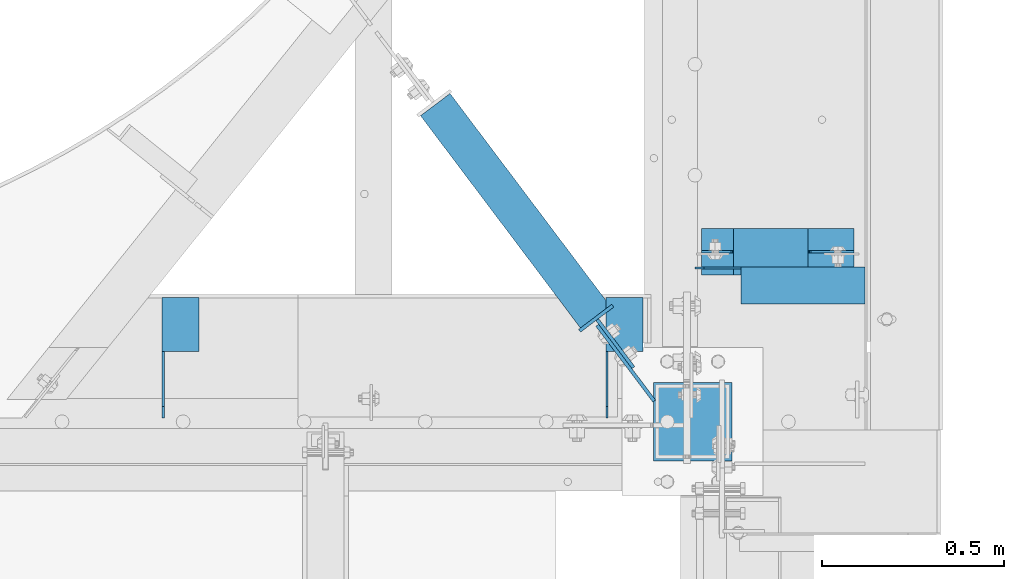
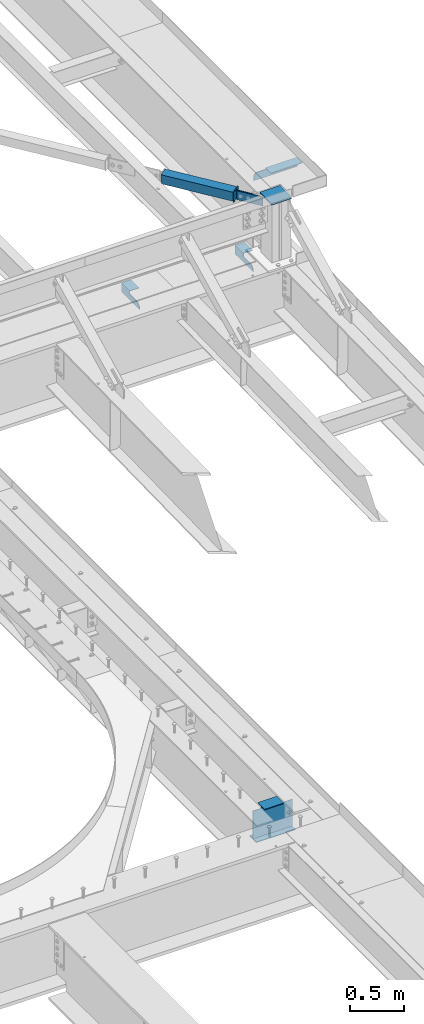
# One storey, part 1377 of 1763: 9 beams, 5 elements without a shape of their own.
"""IFC2X3 building model written with IfcOpenShell, lengths in millimetres."""

from ifc_helpers import new_model, si_unit, frame, origin_with_axes, place, context, subcontext, project, spatial, faceted_brep, material, type_object, element, aggregate, save


model = new_model("IFC2X3")

# Units and contexts
model_context = context("Model", 3, precision=1e-05, world=origin_with_axes())
body_context = subcontext(model_context, "Body", "Model", "MODEL_VIEW")
ifc_project = project(units=[si_unit("LENGTHUNIT", "METRE", prefix="MILLI"), si_unit("AREAUNIT", "SQUARE_METRE"), si_unit("VOLUMEUNIT", "CUBIC_METRE"), si_unit("MASSUNIT", "GRAM", prefix="KILO"), si_unit("TIMEUNIT", "SECOND"), si_unit("PLANEANGLEUNIT", "RADIAN"), si_unit("SOLIDANGLEUNIT", "STERADIAN"), si_unit("THERMODYNAMICTEMPERATUREUNIT", "DEGREE_CELSIUS"), si_unit("LUMINOUSINTENSITYUNIT", "LUMEN")], contexts=[model_context])

# Site, building, storey
site_placement = place(None, origin_with_axes())
site = spatial("IfcSite", under=ifc_project, at=site_placement, CompositionType="ELEMENT")
building_placement = place(site_placement, origin_with_axes())
building = spatial("IfcBuilding", under=site, at=building_placement, Name="Undefined", CompositionType="ELEMENT")
storey_placement = place(building_placement, origin_with_axes())
storey = spatial("IfcBuildingStorey", under=building, at=storey_placement, Name="Undefined", CompositionType="ELEMENT", Elevation=0.0)

# Assembly, beam
assembly_1_placement = place(storey_placement, origin_with_axes())
assembly_1 = element("IfcElementAssembly", 1, at=assembly_1_placement, inside=storey, Name="BEAM", AssemblyPlace="NOTDEFINED", PredefinedType="RIGID_FRAME")
ifc_material_1 = material(Name="STEEL/A36")
beam_type_1 = type_object("IfcBeamType", Name="L4X4X1/4", PredefinedType="NOTDEFINED")
beam_1_placement = place(assembly_1_placement, frame((-21196.9646113448, 52495.4499880058, 12395.2), z_axis=(0.0, 0.0, -1.0), x_axis=(-1.0, 0.0, 0.0)))
beam_1 = element("IfcBeam", 2, at=beam_1_placement, type_object=beam_type_1, material=ifc_material_1, Name="BRACE", ObjectType="L4X4X1/4", context=body_context, shape_type="Brep", body=[
    faceted_brep([(1.96450855582952e-10, -50.8000000000338, -44.4499999999534), (2.11002770811319e-10, -50.8000000000357, -50.799999999952), (339.725506103507, -50.8000000000029, -50.7999999999993), (339.725506103507, -50.8000000000029, -44.4500000000007), (-3.63797880709171e-11, 50.8000000000011, -50.8000000000538), (339.725506103507, 50.8000000000029, -50.7999999999993), (339.725506103507, 44.4499999999971, -34.9250007629398), (339.725506103507, 50.8000000000029, -34.9250007629398), (441.325002944937, 50.8000000000029, -34.9250007629398), (441.325002944937, 44.4499999999971, -34.9250007629398), (339.725506103507, 44.4499999999971, -44.4500000000007), (-2.18278728425503e-11, 44.4500000000007, -44.450000000048), (-1.81898940354586e-10, 44.4500000000371, 50.7999999999374), (-1.96450855582952e-10, 50.8000000000393, 50.7999999999374), (466.725006103512, 44.4499999999971, 50.7999999999993), (466.725006103512, 50.8000000000029, 50.7999999999993), (466.725002563468, 50.8000000000029, -9.52499923706091), (466.725002563468, 44.4499999999971, -9.52499923706091)], [[[0, 1, 2, 3]], [[1, 4, 5, 2]], [[6, 7, 8, 9]], [[10, 3, 2, 5, 7, 6]], [[11, 0, 3, 10]], [[1, 0, 11, 12, 13, 4]], [[13, 12, 14, 15]], [[8, 7, 5, 4, 13, 15, 16]], [[9, 8, 16, 17]], [[12, 11, 10, 6, 9, 17, 14]], [[16, 15, 14, 17]]]),
])
aggregate(assembly_1, [beam_1])

# Assembly, beams
assembly_2_placement = place(storey_placement, origin_with_axes())
assembly_2 = element("IfcElementAssembly", 3, at=assembly_2_placement, inside=storey, Name="BEAM", AssemblyPlace="NOTDEFINED", PredefinedType="RIGID_FRAME")
beam_2_placement = place(assembly_2_placement, frame((-21857.7247736984, 52462.1124819023, 11696.6999917654), z_axis=(0.0, 0.0, -1.0), x_axis=(0.0, -1.0, 0.0)))
beam_2 = element("IfcBeam", 4, at=beam_2_placement, type_object=beam_type_1, material=ifc_material_1, Name="BRACE", ObjectType="L4X4X1/4", context=body_context, shape_type="Brep", body=[
    faceted_brep([(330.993731689443, 44.4500000000007, 19.050000000012), (299.243731689443, 44.4499999999971, -12.7000043904281), (299.243731689443, 50.7999999999993, -12.7000043904281), (330.993731689443, 50.7999999999993, 19.050000000012), (1.96450855582952e-10, -50.8000000000338, -44.4499999999534), (2.11002770811319e-10, -50.8000000000357, -50.799999999952), (148.431790785675, -50.7999999999993, -50.7999999999993), (148.431790430077, -50.7999999999993, -44.4500000000007), (-3.63797880709171e-11, 50.8000000000011, -50.8000000000538), (148.43173094331, 50.7999999999993, -50.7999999999993), (148.43173432786, 44.4500000000007, -44.4500000000007), (148.431728809323, 50.7999999999993, -12.6999970794623), (148.431732549492, 44.4500000000007, -12.6999970794623), (-2.18278728425503e-11, 44.4500000000007, -44.450000000048), (-1.81898940354586e-10, 44.4500000000371, 50.7999999999374), (-1.96450855582952e-10, 50.8000000000393, 50.7999999999374), (330.993731689443, 44.4500000000007, 50.7999999999993), (330.993731689443, 50.7999999999993, 50.7999999999993)], [[[0, 1, 2, 3]], [[4, 5, 6, 7]], [[5, 8, 9, 6]], [[10, 7, 6, 9, 11, 12]], [[13, 4, 7, 10]], [[5, 4, 13, 14, 15, 8]], [[15, 14, 16, 17]], [[17, 16, 0, 3]], [[11, 9, 8, 15, 17, 3, 2]], [[12, 11, 2, 1]], [[16, 14, 13, 10, 12, 1, 0]]]),
])
beam_3_placement = place(assembly_2_placement, frame((-23076.9247736984, 52462.1124819023, 11696.6999917654), z_axis=(0.0, 0.0, -1.0), x_axis=(0.0, -1.0, 0.0)))
beam_3 = element("IfcBeam", 5, at=beam_3_placement, type_object=beam_type_1, material=ifc_material_1, Name="BRACE", ObjectType="L4X4X1/4", context=body_context, shape_type="Brep", body=[
    faceted_brep([(148.43173432786, 44.4500000000007, -44.4500000000007), (148.431790430077, -50.7999999999993, -44.4500000000007), (148.431790785675, -50.7999999999993, -50.7999999999993), (148.43173094331, 50.7999999999993, -50.7999999999993), (148.431728809323, 50.7999999999993, -12.6999970794623), (148.431732549492, 44.4500000000007, -12.6999970794623), (299.243731689443, 50.7999999999993, -12.7000043904281), (299.243731689443, 44.4499999999971, -12.7000043904281), (2.11002770811319e-10, -50.8000000000357, -50.799999999952), (1.96450855582952e-10, -50.8000000000338, -44.4499999999534), (-2.18278728425503e-11, 44.4500000000007, -44.450000000048), (-1.81898940354586e-10, 44.4500000000371, 50.7999999999374), (-1.96450855582952e-10, 50.8000000000393, 50.7999999999374), (-3.63797880709171e-11, 50.8000000000011, -50.8000000000538), (330.993731689443, 44.4500000000007, 50.7999999999993), (330.993731689443, 50.7999999999993, 50.7999999999993), (330.993731689443, 44.4500000000007, 19.050000000012), (330.993731689443, 50.7999999999993, 19.050000000012)], [[[0, 1, 2, 3, 4, 5]], [[5, 4, 6, 7]], [[8, 9, 10, 11, 12, 13]], [[12, 11, 14, 15]], [[15, 14, 16, 17]], [[16, 7, 6, 17]], [[4, 3, 13, 12, 15, 17, 6]], [[8, 13, 3, 2]], [[9, 8, 2, 1]], [[10, 9, 1, 0]], [[14, 11, 10, 0, 5, 7, 16]]]),
])
aggregate(assembly_2, [beam_2, beam_3])

# Assembly, beam
assembly_3_placement = place(storey_placement, origin_with_axes())
assembly_3 = element("IfcElementAssembly", 6, at=assembly_3_placement, inside=storey, Name="COLUMN", AssemblyPlace="NOTDEFINED", PredefinedType="RIGID_FRAME")
beam_type_2 = type_object("IfcBeamType", PredefinedType="NOTDEFINED")
beam_4_placement = place(assembly_3_placement, frame((-21853.7716613972, 52281.4233268731, 12422.1875), z_axis=(0.601714169057071, -0.798711499075829, 0.0), x_axis=(0.0, 0.0, -1.0)))
beam_4 = element("IfcBeam", 7, at=beam_4_placement, type_object=beam_type_2, material=ifc_material_1, Name="PLATE", context=body_context, shape_type="Brep", body=[
    faceted_brep([(0.0, 4.76250000039727, -130.17499999985), (0.0, 4.76250000000073, 130.175003051758), (101.599999999999, 4.76249999958964, 130.174999999839), (101.599999999999, 4.76250000039727, -130.17499999985), (0.0, -4.76250000000073, 130.175003051758), (101.599999999999, -4.7625000004191, 130.174999999828), (0.0, -4.76249999961874, -130.174999999857), (101.599999999999, -4.76249999961874, -130.174999999857)], [[[0, 1, 2, 3]], [[1, 4, 5, 2]], [[4, 6, 7, 5]], [[6, 0, 3, 7]], [[5, 7, 3, 2]], [[6, 4, 1, 0]]]),
])

# Assembly, beams
assembly_4_placement = place(storey_placement, origin_with_axes())
assembly_4 = element("IfcElementAssembly", 8, at=assembly_4_placement, inside=storey, Name="H. BRACE", AssemblyPlace="NOTDEFINED", PredefinedType="RIGID_FRAME")
beam_5_placement = place(assembly_4_placement, frame((-21882.4452816829, 52335.3143133173, 12422.1875), z_axis=(0.601714169057071, -0.798711499075829, 0.0), x_axis=(0.0, 0.0, -1.0)))
beam_5 = element("IfcBeam", 9, at=beam_5_placement, type_object=beam_type_2, material=ifc_material_1, Name="PLATE", context=body_context, shape_type="Brep", body=[
    faceted_brep([(0.0, 4.7625000001417, -82.5500000001048), (0.0, 4.76249999986885, 82.5500000001339), (101.599999999999, 4.76249999986885, 82.5500000001339), (101.599999999999, 4.7625000001417, -82.5500000001048), (0.0, -4.76250000014352, 82.5500000001193), (101.599999999999, -4.76250000014352, 82.5500000001193), (0.0, -4.76249999987067, -82.5500000001193), (101.599999999999, -4.76249999987067, -82.5500000001193)], [[[0, 1, 2, 3]], [[1, 4, 5, 2]], [[4, 6, 7, 5]], [[6, 0, 3, 7]], [[5, 7, 3, 2]], [[6, 4, 1, 0]]]),
])
ifc_material_2 = material()
beam_type_3 = type_object("IfcBeamType", Name="HSS4X4X3/8", PredefinedType="NOTDEFINED")
beam_6_placement = place(assembly_4_placement, frame((-21720.839617887, 52120.7999996695, 12371.3875), z_axis=(-0.798711499075791, -0.601714169057122, 0.0), x_axis=(-0.601714169057124, 0.798711499075789, 0.0)))
beam_6 = element("IfcBeam", 10, at=beam_6_placement, type_object=beam_type_3, material=ifc_material_2, Name="H. BRACE", ObjectType="HSS4X4X3/8", context=body_context, shape_type="Brep", body=[
    faceted_brep([(360.650466735329, 41.2749999999996, -41.2749999998196), (360.650466735329, -41.2749999999996, -41.2749999998196), (1090.48049943776, -41.2749999999996, -41.2749999996486), (1090.48049943776, 41.2749999999996, -41.2749999996486), (360.650466735562, -41.2749999999996, 41.2749999999905), (1090.48049943801, -41.2749999999996, 41.2750000001615), (360.650466735562, 41.2749999999996, 41.2749999999905), (1090.48049943801, 41.2749999999996, 41.2750000001615), (360.6504667353, 50.7999999999993, -50.7999999997992), (360.650466735591, 50.7999999999993, 50.7999999999665), (1090.48049943802, 50.7999999999993, 50.8000000001375), (1090.48049943774, 50.7999999999993, -50.7999999996282), (360.650466735591, -50.7999999999993, 50.7999999999665), (1090.48049943802, -50.7999999999993, 50.8000000001375), (360.6504667353, -50.7999999999993, -50.7999999997992), (1090.48049943774, -50.7999999999993, -50.7999999996282)], [[[0, 1, 2, 3]], [[1, 4, 5, 2]], [[4, 6, 7, 5]], [[6, 0, 3, 7]], [[8, 9, 10, 11]], [[9, 12, 13, 10]], [[12, 14, 15, 13]], [[14, 8, 11, 15]], [[13, 15, 11, 10], [5, 7, 3, 2]], [[14, 12, 9, 8], [6, 4, 1, 0]]]),
])
beam_type_4 = type_object("IfcBeamType", PredefinedType="NOTDEFINED")
beam_7_placement = place(assembly_4_placement, frame((-21934.982450069, 52405.0518110801, 12428.5375), z_axis=(0.79871149907583, 0.601714169057071, 0.0), x_axis=(0.0, 0.0, -1.0)))
beam_7 = element("IfcBeam", 11, at=beam_7_placement, type_object=beam_type_4, material=ifc_material_1, Name="PLATE", context=body_context, shape_type="Brep", body=[
    faceted_brep([(0.0, 4.76249999989523, -57.1500000001702), (0.0, 4.76250000014261, 57.1500000001565), (114.299999999999, 4.76250000014261, 57.1500000001565), (114.299999999999, 4.76249999989523, -57.1500000001702), (0.0, -4.76249999988067, 57.1500000001784), (114.299999999999, -4.76249999988067, 57.1500000001784), (0.0, -4.76250000012806, -57.150000000152), (114.299999999999, -4.76250000012806, -57.150000000152)], [[[0, 1, 2, 3]], [[1, 4, 5, 2]], [[4, 6, 7, 5]], [[6, 0, 3, 7]], [[5, 7, 3, 2]], [[6, 4, 1, 0]]]),
])
aggregate(assembly_4, [beam_7, beam_5, beam_6])

# Assembly, beam
assembly_5_placement = place(storey_placement, origin_with_axes())
assembly_5 = element("IfcElementAssembly", 12, at=assembly_5_placement, inside=storey, Name="BEAM", AssemblyPlace="NOTDEFINED", PredefinedType="RIGID_FRAME")
ifc_material_3 = material(Name="STEEL/A992")
beam_type_5 = type_object("IfcBeamType", Name="W14X22", PredefinedType="NOTDEFINED")
beam_8_placement = place(assembly_5_placement, frame((-21663.6896174484, 52587.5425415639, 5019.675), z_axis=(0.0, 0.0, 1.0), x_axis=(1.0, 0.0, 0.0)))
beam_8 = element("IfcBeam", 13, at=beam_8_placement, type_object=beam_type_5, material=ifc_material_3, Name="BEAM", ObjectType="W14X22", context=body_context, shape_type="Brep", body=[
    faceted_brep([(310.356250000001, -63.5, 174.625), (310.356250000001, -63.5, 166.6875), (310.356250000001, -3.17500000000291, 166.6875), (310.356250000001, -3.17500000000291, 148.965001487732), (310.356250000001, 3.17500000000291, 148.965001487732), (310.356250000001, 3.17500000000291, 166.6875), (310.356250000001, 63.5, 166.6875), (310.356250000001, 63.5, 174.625), (311.322979922588, -3.17500000000291, 144.104921969686), (311.322979922588, 3.17500000000291, 144.104921969686), (314.075993823066, -3.17500000000291, 139.984745501532), (314.075993823066, 3.17500000000291, 139.984745501532), (318.196170291219, -3.17500000000291, 137.231731601054), (318.196170291219, 3.17500000000291, 137.231731601054), (323.056249809266, -3.17500000000291, 136.265001678466), (323.056249809266, 3.17500000000291, 136.265001678466), (437.356250000001, -3.17500000000291, 136.265001678466), (437.356250000001, 3.17500000000291, 136.265001678466), (106.362500000007, -63.5, 174.625), (106.362500000007, 63.5, 174.625), (106.362500000007, 63.5, 166.6875), (106.362500000007, 3.17500000000291, 166.6875), (106.362500000007, 3.17500000000291, 161.665001487732), (106.362500000007, -3.17500000000291, 161.665001487732), (106.362500000007, -3.17500000000291, 166.6875), (106.362500000007, -63.5, 166.6875), (105.395770077419, 3.17500000000291, 156.804921969687), (105.395770077419, -3.17500000000291, 156.804921969687), (102.642756176941, 3.17500000000291, 152.684745501533), (102.642756176941, -3.17500000000291, 152.684745501533), (98.5225797087878, 3.17500000000291, 149.931731601055), (98.5225797087878, -3.17500000000291, 149.931731601055), (93.6625001907414, 3.17500000000291, 148.965001678467), (93.6625001907414, -3.17500000000291, 148.965001678467), (17.4625000000015, 3.17500000000291, 148.965001678467), (17.4625000000015, -3.17500000000291, 148.965001678467), (17.4625000000015, 3.17500000000291, -166.6875), (17.4625000000015, 63.5, -166.6875), (17.4625000000015, 63.5, -174.625), (17.4625000000015, -63.5, -174.625), (17.4625000000015, -63.5, -166.6875), (17.4625000000015, -3.17500000000291, -166.6875), (437.356250000001, 3.17500000000291, -166.6875), (437.356250000001, 63.5, -166.6875), (437.356250000001, 63.5, -174.625), (437.356250000001, -63.5, -174.625), (437.356250000001, -63.5, -166.6875), (437.356250000001, -3.17500000000291, -166.6875)], [[[0, 1, 2, 3, 4, 5, 6, 7]], [[8, 9, 4, 3]], [[10, 11, 9, 8]], [[12, 13, 11, 10]], [[14, 15, 13, 12]], [[16, 17, 15, 14]], [[18, 19, 20, 21, 22, 23, 24, 25]], [[23, 22, 26, 27]], [[27, 26, 28, 29]], [[29, 28, 30, 31]], [[31, 30, 32, 33]], [[33, 32, 34, 35]], [[36, 37, 38, 39, 40, 41, 35, 34]], [[37, 36, 42, 43]], [[38, 37, 43, 44]], [[39, 38, 44, 45]], [[40, 39, 45, 46]], [[41, 40, 46, 47]], [[12, 10, 8, 3, 2, 24, 23, 27, 29, 31, 33, 35, 41, 47, 16, 14]], [[25, 24, 2, 1]], [[18, 25, 1, 0]], [[19, 18, 0, 7]], [[20, 19, 7, 6]], [[21, 20, 6, 5]], [[42, 36, 34, 32, 30, 28, 26, 22, 21, 5, 4, 9, 11, 13, 15, 17]], [[47, 46, 45, 44, 43, 42, 17, 16]]]),
])
aggregate(assembly_5, [beam_8])

# Beam
beam_type_6 = type_object("IfcBeamType", PredefinedType="NOTDEFINED")
beam_9_placement = place(assembly_3_placement, frame((-21562.0896174484, 52120.800000001, 12436.475), z_axis=(0.0, 1.0, 0.0), x_axis=(-1.0, 0.0, 0.0)))
beam_9 = element("IfcBeam", 14, at=beam_9_placement, type_object=beam_type_6, material=ifc_material_1, Name="PLATE", context=body_context, shape_type="Brep", body=[
    faceted_brep([(0.0, 9.52499999999964, -107.949999999997), (0.0, 9.52499999999964, 107.949999999997), (215.899999999994, 9.52499999999964, 107.949999999997), (215.899999999994, 9.52499999999964, -107.949999999997), (0.0, -9.52499999999964, 107.949999999997), (215.899999999994, -9.52499999999964, 107.949999999997), (0.0, -9.52499999999964, -107.949999999997), (215.899999999994, -9.52499999999964, -107.949999999997)], [[[0, 1, 2, 3]], [[1, 4, 5, 2]], [[4, 6, 7, 5]], [[6, 0, 3, 7]], [[5, 7, 3, 2]], [[6, 4, 1, 0]]]),
])

aggregate(assembly_3, [beam_4, beam_9])

save(model, "model.ifc")
